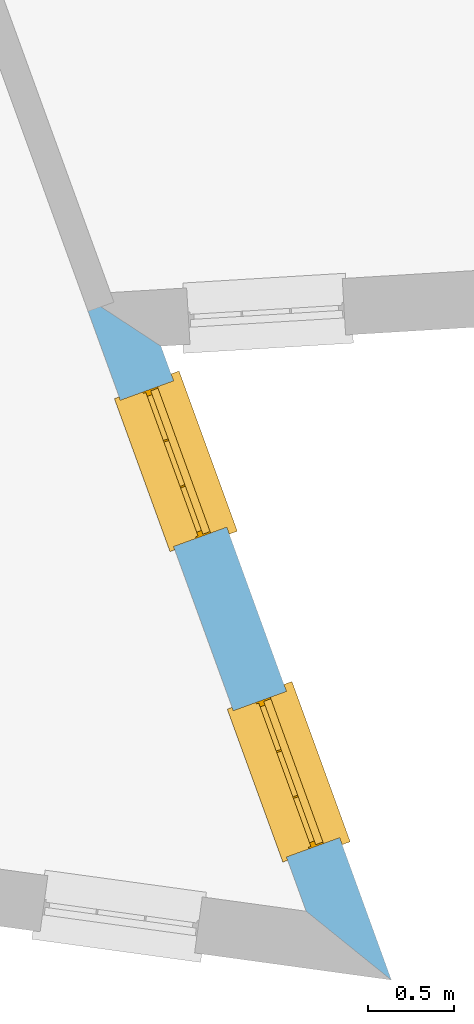
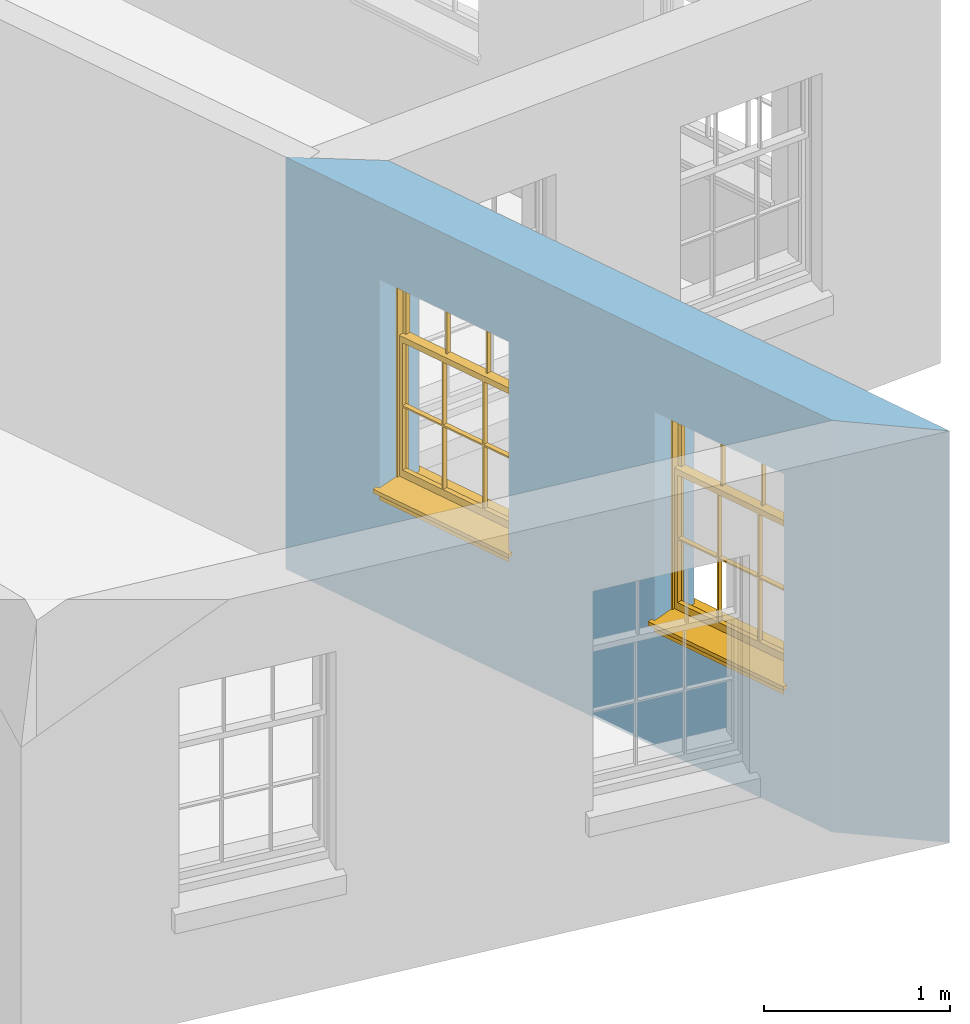
# One storey, part 4 of 12: 2 windows, 2 openings, plus 1 element that does not belong to this part.
"""IFC2X3 building model written with IfcOpenShell, lengths in metres."""

from ifc_helpers import new_model, si_unit, frame, origin, place, context, subcontext, project, spatial, polyline, outline, extrude, faceted_brep, material, layer, layer_set, layer_usage, element, fill, save


model = new_model("IFC2X3")

# Units and contexts
model_context = context("Model", 3, world=origin())
body_context = subcontext(model_context, "Body", "Model", "MODEL_VIEW")
ifc_project = project(units=[si_unit("PLANEANGLEUNIT", "RADIAN"), si_unit("MASSUNIT", "GRAM", prefix="KILO"), si_unit("FORCEUNIT", "NEWTON", prefix="KILO"), si_unit("LENGTHUNIT", "METRE")], contexts=[model_context])

# Site, building, storey
site_placement = place(None, origin())
site = spatial("IfcSite", under=ifc_project, at=site_placement, CompositionType="ELEMENT")
building_placement = place(None, origin())
building = spatial("IfcBuilding", under=site, at=building_placement, Name="Building plot-12", CompositionType="ELEMENT")
storey_placement = place(None, frame((0.0, 0.0, 6.45)))
storey = spatial("IfcBuildingStorey", under=building, at=storey_placement, Name="Floor 1", CompositionType="ELEMENT", Elevation=6.45)

# Wall, openings, windows
ifc_material = material(Name="Masonry")
ifc_layer = layer(ifc_material, 0.33, ventilated=False)
ifc_layer_set = layer_set([ifc_layer], Name="My Wall")
ifc_layer_usage = layer_usage(ifc_layer_set, "AXIS2", "NEGATIVE", 0.08)
wall_placement = place(storey_placement, origin())
wall = element("IfcWallStandardCase", 1, at=wall_placement, inside=storey, material=ifc_layer_usage, Name="exterior", context=body_context, shape_type="SweptSolid", body=[
    extrude(outline(polyline([(60.357257872223, 31.2577442307242), (60.8543376208598, 30.856304618938), (59.5092760501621, 34.5560013261806), (59.0480704661197, 34.8587662516055), (60.357257872223, 31.2577442307242)])), origin(), (0.0, 0.0, 1.0), 2.7),
])
opening_1_placement = place(storey_placement, frame((0.0, 0.0, 0.75)))
opening_1 = element("IfcOpeningElement", 2, at=opening_1_placement, cuts=wall, Name="Opening", ObjectType="Opening", context=body_context, shape_type="SweptSolid", body=[
    extrude(outline(polyline([(60.5526263615271, 31.6861849582538), (60.241697889756, 32.541417958928), (59.9315584499511, 32.4286636779561), (60.2424869217222, 31.5734306772819), (60.5526263615271, 31.6861849582538)])), origin(), (0.0, 0.0, 1.0), 1.445),
])
opening_2_placement = place(storey_placement, frame((0.0, 0.0, 0.75)))
opening_2 = element("IfcOpeningElement", 3, at=opening_2_placement, cuts=wall, Name="Opening", ObjectType="Opening", context=body_context, shape_type="SweptSolid", body=[
    extrude(outline(polyline([(59.8936842748883, 33.4986565367382), (59.5827558031172, 34.3538895374124), (59.2726163633123, 34.2411352564405), (59.5835448350833, 33.3859022557663), (59.8936842748883, 33.4986565367382)])), origin(), (0.0, 0.0, 1.0), 1.445),
])
window_1_placement = place(storey_placement, frame((60.3176722404628, 31.6007650484266, 0.75), z_axis=(0.0, 0.0, 1.0), x_axis=(-0.310928471771057, 0.855233000674151, 0.0)))
window_1 = element("IfcWindow", 4, at=window_1_placement, inside=storey, Name="living outside window", OverallHeight=1.445, OverallWidth=0.91, context=body_context, shape_type="Brep", held_by="IfcProductRepresentation", body=[
    faceted_brep([(0.876875, -0.105, 0.999097), (0.876875, -0.105, 1.411875), (0.9, -0.105, 1.435), (0.033125, -0.105, 1.411875), (0.033125, -0.105, 0.999097), (0.01, -0.105, 1.435), (0.033125, -0.135, 1.411875), (0.01, -0.135, 1.435), (0.033125, -0.135, 0.999097), (0.876875, -0.135, 1.411875), (0.876875, -0.135, 0.999097), (0.9, -0.135, 1.435), (0.033125, -0.105, 0.960972), (0.01, -0.105, 0.960972), (0.033125, -0.105, 0.548195), (0.876875, -0.105, 0.960972), (0.876875, -0.105, 0.548195), (0.9, -0.105, 0.960972), (0.876875, -0.105, 0.538195), (0.876875, -0.105, 0.125417), (0.9, -0.105, 0.077167), (0.033125, -0.105, 0.125417), (0.033125, -0.105, 0.538195), (0.01, -0.105, 0.077167), (0.9, -0.135, 0.960972), (0.01, -0.135, 0.960972), (-0.0425, -0.25, 0.01), (-0.0425, -0.3, 0.001667), (0.0, -0.25, 0.01), (0.9525, -0.25, 0.01), (0.91, -0.25, 0.01), (0.9525, -0.3, 0.001667), (-0.02, 0.08, 0.077167), (0.0, 0.08, 0.077167), (-0.02, 0.11, 0.077167), (0.0, -0.06, 0.077167), (0.01, -0.06, 0.077167), (0.91, -0.06, 0.077167), (0.91, 0.08, 0.077167), (0.9, -0.06, 0.077167), (0.93, 0.08, 0.077167), (0.93, 0.11, 0.077167), (0.01, -0.105, 0.999097), (0.01, -0.075, 0.999097), (0.9, -0.105, 0.999097), (0.9, -0.075, 0.999097), (0.876875, -0.075, 0.125417), (0.876875, -0.075, 0.538195), (0.9, -0.075, 0.077167), (0.876875, -0.075, 0.548195), (0.876875, -0.075, 0.960972), (0.033125, -0.075, 0.125417), (0.01, -0.075, 0.077167), (0.033125, -0.075, 0.538195), (0.033125, -0.075, 0.960972), (0.033125, -0.075, 0.548195), (-0.02, 0.08, 0.052167), (-0.02, 0.11, 0.052167), (0.93, 0.11, 0.052167), (0.93, 0.08, 0.052167), (0.91, 0.08, 0.052167), (0.0, 0.08, 0.052167), (0.91, -0.15, 0.026667), (0.0, -0.15, 0.026667), (-0.0425, -0.3, -0.123333), (0.9525, -0.3, -0.123333), (-0.0425, -0.25, -0.123333), (0.9525, -0.25, -0.123333), (0.01, -0.06, 1.435), (0.9, -0.06, 1.435), (0.0, -0.06, 1.445), (0.91, -0.06, 1.445), (0.01, -0.15, 0.077167), (0.9, -0.15, 0.077167), (0.592292, -0.105, 0.125417), (0.592292, -0.075, 0.125417), (0.317708, -0.075, 0.125417), (0.317708, -0.105, 0.125417), (0.592292, -0.105, 0.548195), (0.317708, -0.105, 0.548195), (0.317708, -0.105, 0.538195), (0.592292, -0.105, 0.538195), (0.592292, -0.075, 0.548195), (0.317708, -0.075, 0.548195), (0.602292, -0.075, 0.548195), (0.602292, -0.105, 0.548195), (0.317708, -0.075, 0.538195), (0.307708, -0.075, 0.125417), (0.307708, -0.075, 0.538195), (0.602292, -0.075, 0.538195), (0.602292, -0.075, 0.125417), (0.592292, -0.075, 0.538195), (0.307708, -0.075, 0.548195), (0.317708, -0.075, 0.960972), (0.307708, -0.075, 0.960972), (0.602292, -0.075, 0.960972), (0.592292, -0.075, 0.960972), (0.307708, -0.105, 0.538195), (0.307708, -0.105, 0.125417), (0.307708, -0.105, 0.548195), (0.307708, -0.105, 0.960972), (0.592292, -0.105, 0.960972), (0.317708, -0.105, 0.960972), (0.602292, -0.105, 0.960972), (0.602292, -0.105, 0.538195), (0.602292, -0.105, 0.125417), (0.317708, -0.135, 1.411875), (0.307708, -0.135, 1.411875), (0.307708, -0.135, 0.999097), (0.317708, -0.135, 0.999097), (0.602292, -0.135, 1.411875), (0.592292, -0.135, 1.411875), (0.592292, -0.135, 0.999097), (0.602292, -0.135, 0.999097), (0.317708, -0.105, 0.999097), (0.307708, -0.105, 0.999097), (0.307708, -0.105, 1.411875), (0.317708, -0.105, 1.411875), (0.602292, -0.105, 0.999097), (0.592292, -0.105, 0.999097), (0.592292, -0.105, 1.411875), (0.602292, -0.105, 1.411875), (0.91, -0.15, 1.445), (0.9, -0.15, 1.435), (0.01, -0.15, 1.435), (0.0, -0.15, 1.445), (0.91, -0.25, 0.0), (0.0, -0.25, 0.0), (0.91, 0.08, 0.0), (0.0, 0.08, 0.0)], [[[0, 1, 2]], [[3, 4, 5]], [[6, 7, 8]], [[9, 10, 11]], [[12, 13, 14]], [[15, 16, 17]], [[18, 19, 20]], [[21, 22, 23]], [[24, 15, 17]], [[13, 12, 25]], [[26, 27, 28]], [[29, 30, 31]], [[32, 33, 34]], [[35, 36, 33]], [[37, 38, 39]], [[40, 41, 38]], [[42, 4, 43]], [[44, 45, 0]], [[46, 47, 48]], [[49, 50, 45]], [[51, 52, 53]], [[54, 55, 43]], [[38, 33, 36, 39]], [[41, 34, 33, 38]], [[56, 32, 34, 57]], [[57, 34, 41, 58]], [[58, 41, 40, 59]], [[57, 58, 60, 61]], [[52, 48, 39, 36]], [[62, 63, 28, 30]], [[27, 31, 30, 28]], [[27, 64, 65, 31]], [[66, 67, 65, 64]], [[2, 5, 68, 69]], [[68, 70, 71, 69]], [[20, 23, 72, 73]], [[73, 72, 63, 62]], [[74, 75, 76, 77]], [[78, 79, 80, 81]], [[78, 82, 83, 79]], [[16, 49, 84, 85]], [[86, 76, 87, 88]], [[89, 90, 75, 91]], [[92, 88, 53, 55]], [[82, 91, 86, 83]], [[93, 83, 92, 94]], [[95, 84, 82, 96]], [[89, 84, 49, 47]], [[97, 88, 87, 98]], [[22, 53, 88, 97]], [[81, 91, 75, 74]], [[80, 86, 91, 81]], [[77, 76, 86, 80]], [[99, 92, 55, 14]], [[100, 94, 92, 99]], [[101, 96, 82, 78]], [[79, 83, 93, 102]], [[85, 84, 95, 103]], [[104, 89, 47, 18]], [[105, 90, 89, 104]], [[104, 18, 16, 85]], [[80, 97, 98, 77]], [[104, 81, 74, 105]], [[103, 101, 78, 85]], [[99, 14, 22, 97]], [[102, 100, 99, 79]], [[106, 107, 108, 109]], [[110, 111, 112, 113]], [[114, 115, 116, 117]], [[118, 119, 120, 121]], [[107, 116, 115, 108]], [[111, 120, 119, 112]], [[109, 114, 117, 106]], [[113, 118, 121, 110]], [[85, 78, 81, 104]], [[84, 89, 91, 82]], [[83, 86, 88, 92]], [[79, 99, 97, 80]], [[109, 112, 119, 114]], [[102, 93, 96, 101]], [[106, 117, 120, 111]], [[98, 87, 51, 21]], [[6, 3, 116, 107]], [[110, 121, 1, 9]], [[19, 46, 90, 105]], [[26, 66, 64, 27]], [[29, 31, 65, 67]], [[25, 24, 112, 109]], [[11, 7, 106, 111]], [[75, 48, 52, 76]], [[43, 45, 96, 93]], [[45, 43, 114, 119]], [[5, 2, 120, 117]], [[24, 25, 102, 101]], [[42, 5, 4]], [[2, 44, 0]], [[49, 45, 48, 47]], [[52, 43, 55, 53]], [[14, 13, 23, 22]], [[20, 17, 16, 18]], [[24, 11, 10]], [[25, 8, 7]], [[8, 4, 3, 6]], [[9, 1, 0, 10]], [[15, 50, 49, 16]], [[18, 47, 46, 19]], [[21, 51, 53, 22]], [[14, 55, 54, 12]], [[44, 2, 69, 45]], [[68, 5, 42, 43]], [[36, 35, 70, 68]], [[39, 69, 71, 37]], [[62, 122, 123, 73]], [[63, 72, 124, 125]], [[8, 108, 115, 4]], [[113, 10, 0, 118]], [[94, 100, 12, 54]], [[17, 20, 73, 24]], [[72, 23, 13, 25]], [[52, 36, 68, 43]], [[69, 39, 48, 45]], [[11, 24, 73, 123]], [[7, 124, 72, 25]], [[23, 77, 98]], [[98, 21, 23]], [[105, 74, 20]], [[20, 19, 105]], [[20, 74, 77, 23]], [[113, 112, 24]], [[24, 10, 113]], [[25, 109, 108]], [[108, 8, 25]], [[110, 9, 11]], [[11, 111, 110]], [[7, 6, 107]], [[107, 106, 7]], [[5, 117, 116]], [[116, 3, 5]], [[121, 120, 2]], [[2, 1, 121]], [[11, 123, 124, 7]], [[122, 125, 124, 123]], [[43, 93, 94]], [[94, 54, 43]], [[96, 45, 95]], [[50, 95, 45]], [[15, 103, 95, 50]], [[48, 75, 90]], [[90, 46, 48]], [[87, 76, 52]], [[52, 51, 87]], [[103, 15, 24]], [[24, 101, 103]], [[100, 102, 25]], [[25, 12, 100]], [[115, 114, 43]], [[43, 4, 115]], [[118, 0, 45]], [[45, 119, 118]], [[71, 70, 125, 122]], [[70, 35, 63, 125]], [[122, 62, 37, 71]], [[126, 67, 66, 127]], [[60, 58, 59]], [[38, 60, 59, 40]], [[61, 56, 57]], [[32, 56, 61, 33]], [[61, 60, 128, 129]], [[62, 60, 38, 37]], [[126, 128, 60, 62]], [[33, 61, 63, 35]], [[61, 129, 127, 63]], [[128, 126, 127, 129]], [[28, 127, 66, 26]], [[63, 127, 28]], [[29, 67, 126, 30]], [[30, 126, 62]]]),
])
fill(opening_1, window_1)
window_2_placement = place(storey_placement, frame((59.6587301538239, 33.413236626911, 0.75), z_axis=(0.0, 0.0, 1.0), x_axis=(-0.310928471771057, 0.855233000674147, 0.0)))
window_2 = element("IfcWindow", 5, at=window_2_placement, inside=storey, Name="living outside window", OverallHeight=1.445, OverallWidth=0.91, context=body_context, shape_type="Brep", held_by="IfcProductRepresentation", body=[
    faceted_brep([(0.876875, -0.105, 0.999097), (0.876875, -0.105, 1.411875), (0.9, -0.105, 1.435), (0.033125, -0.105, 1.411875), (0.033125, -0.105, 0.999097), (0.01, -0.105, 1.435), (0.033125, -0.135, 1.411875), (0.01, -0.135, 1.435), (0.033125, -0.135, 0.999097), (0.876875, -0.135, 1.411875), (0.876875, -0.135, 0.999097), (0.9, -0.135, 1.435), (0.033125, -0.105, 0.960972), (0.01, -0.105, 0.960972), (0.033125, -0.105, 0.548195), (0.876875, -0.105, 0.960972), (0.876875, -0.105, 0.548195), (0.9, -0.105, 0.960972), (0.876875, -0.105, 0.538195), (0.876875, -0.105, 0.125417), (0.9, -0.105, 0.077167), (0.033125, -0.105, 0.125417), (0.033125, -0.105, 0.538195), (0.01, -0.105, 0.077167), (0.9, -0.135, 0.960972), (0.01, -0.135, 0.960972), (-0.0425, -0.25, 0.01), (-0.0425, -0.3, 0.001667), (0.0, -0.25, 0.01), (0.9525, -0.25, 0.01), (0.91, -0.25, 0.01), (0.9525, -0.3, 0.001667), (-0.02, 0.08, 0.077167), (0.0, 0.08, 0.077167), (-0.02, 0.11, 0.077167), (0.0, -0.06, 0.077167), (0.01, -0.06, 0.077167), (0.91, -0.06, 0.077167), (0.91, 0.08, 0.077167), (0.9, -0.06, 0.077167), (0.93, 0.08, 0.077167), (0.93, 0.11, 0.077167), (0.01, -0.105, 0.999097), (0.01, -0.075, 0.999097), (0.9, -0.105, 0.999097), (0.9, -0.075, 0.999097), (0.876875, -0.075, 0.125417), (0.876875, -0.075, 0.538195), (0.9, -0.075, 0.077167), (0.876875, -0.075, 0.548195), (0.876875, -0.075, 0.960972), (0.033125, -0.075, 0.125417), (0.01, -0.075, 0.077167), (0.033125, -0.075, 0.538195), (0.033125, -0.075, 0.960972), (0.033125, -0.075, 0.548195), (-0.02, 0.08, 0.052167), (-0.02, 0.11, 0.052167), (0.93, 0.11, 0.052167), (0.93, 0.08, 0.052167), (0.91, 0.08, 0.052167), (0.0, 0.08, 0.052167), (0.91, -0.15, 0.026667), (0.0, -0.15, 0.026667), (-0.0425, -0.3, -0.123333), (0.9525, -0.3, -0.123333), (-0.0425, -0.25, -0.123333), (0.9525, -0.25, -0.123333), (0.01, -0.06, 1.435), (0.9, -0.06, 1.435), (0.0, -0.06, 1.445), (0.91, -0.06, 1.445), (0.01, -0.15, 0.077167), (0.9, -0.15, 0.077167), (0.592292, -0.105, 0.125417), (0.592292, -0.075, 0.125417), (0.317708, -0.075, 0.125417), (0.317708, -0.105, 0.125417), (0.592292, -0.105, 0.548195), (0.317708, -0.105, 0.548195), (0.317708, -0.105, 0.538195), (0.592292, -0.105, 0.538195), (0.592292, -0.075, 0.548195), (0.317708, -0.075, 0.548195), (0.602292, -0.075, 0.548195), (0.602292, -0.105, 0.548195), (0.317708, -0.075, 0.538195), (0.307708, -0.075, 0.125417), (0.307708, -0.075, 0.538195), (0.602292, -0.075, 0.538195), (0.602292, -0.075, 0.125417), (0.592292, -0.075, 0.538195), (0.307708, -0.075, 0.548195), (0.317708, -0.075, 0.960972), (0.307708, -0.075, 0.960972), (0.602292, -0.075, 0.960972), (0.592292, -0.075, 0.960972), (0.307708, -0.105, 0.538195), (0.307708, -0.105, 0.125417), (0.307708, -0.105, 0.548195), (0.307708, -0.105, 0.960972), (0.592292, -0.105, 0.960972), (0.317708, -0.105, 0.960972), (0.602292, -0.105, 0.960972), (0.602292, -0.105, 0.538195), (0.602292, -0.105, 0.125417), (0.317708, -0.135, 1.411875), (0.307708, -0.135, 1.411875), (0.307708, -0.135, 0.999097), (0.317708, -0.135, 0.999097), (0.602292, -0.135, 1.411875), (0.592292, -0.135, 1.411875), (0.592292, -0.135, 0.999097), (0.602292, -0.135, 0.999097), (0.317708, -0.105, 0.999097), (0.307708, -0.105, 0.999097), (0.307708, -0.105, 1.411875), (0.317708, -0.105, 1.411875), (0.602292, -0.105, 0.999097), (0.592292, -0.105, 0.999097), (0.592292, -0.105, 1.411875), (0.602292, -0.105, 1.411875), (0.91, -0.15, 1.445), (0.9, -0.15, 1.435), (0.01, -0.15, 1.435), (0.0, -0.15, 1.445), (0.91, -0.25, 0.0), (0.0, -0.25, 0.0), (0.91, 0.08, 0.0), (0.0, 0.08, 0.0)], [[[0, 1, 2]], [[3, 4, 5]], [[6, 7, 8]], [[9, 10, 11]], [[12, 13, 14]], [[15, 16, 17]], [[18, 19, 20]], [[21, 22, 23]], [[24, 15, 17]], [[13, 12, 25]], [[26, 27, 28]], [[29, 30, 31]], [[32, 33, 34]], [[35, 36, 33]], [[37, 38, 39]], [[40, 41, 38]], [[42, 4, 43]], [[44, 45, 0]], [[46, 47, 48]], [[49, 50, 45]], [[51, 52, 53]], [[54, 55, 43]], [[38, 33, 36, 39]], [[41, 34, 33, 38]], [[56, 32, 34, 57]], [[57, 34, 41, 58]], [[58, 41, 40, 59]], [[57, 58, 60, 61]], [[52, 48, 39, 36]], [[62, 63, 28, 30]], [[27, 31, 30, 28]], [[27, 64, 65, 31]], [[66, 67, 65, 64]], [[2, 5, 68, 69]], [[68, 70, 71, 69]], [[20, 23, 72, 73]], [[73, 72, 63, 62]], [[74, 75, 76, 77]], [[78, 79, 80, 81]], [[78, 82, 83, 79]], [[16, 49, 84, 85]], [[86, 76, 87, 88]], [[89, 90, 75, 91]], [[92, 88, 53, 55]], [[82, 91, 86, 83]], [[93, 83, 92, 94]], [[95, 84, 82, 96]], [[89, 84, 49, 47]], [[97, 88, 87, 98]], [[22, 53, 88, 97]], [[81, 91, 75, 74]], [[80, 86, 91, 81]], [[77, 76, 86, 80]], [[99, 92, 55, 14]], [[100, 94, 92, 99]], [[101, 96, 82, 78]], [[79, 83, 93, 102]], [[85, 84, 95, 103]], [[104, 89, 47, 18]], [[105, 90, 89, 104]], [[104, 18, 16, 85]], [[80, 97, 98, 77]], [[104, 81, 74, 105]], [[103, 101, 78, 85]], [[99, 14, 22, 97]], [[102, 100, 99, 79]], [[106, 107, 108, 109]], [[110, 111, 112, 113]], [[114, 115, 116, 117]], [[118, 119, 120, 121]], [[107, 116, 115, 108]], [[111, 120, 119, 112]], [[109, 114, 117, 106]], [[113, 118, 121, 110]], [[85, 78, 81, 104]], [[84, 89, 91, 82]], [[83, 86, 88, 92]], [[79, 99, 97, 80]], [[109, 112, 119, 114]], [[102, 93, 96, 101]], [[106, 117, 120, 111]], [[98, 87, 51, 21]], [[6, 3, 116, 107]], [[110, 121, 1, 9]], [[19, 46, 90, 105]], [[26, 66, 64, 27]], [[29, 31, 65, 67]], [[25, 24, 112, 109]], [[11, 7, 106, 111]], [[75, 48, 52, 76]], [[43, 45, 96, 93]], [[45, 43, 114, 119]], [[5, 2, 120, 117]], [[24, 25, 102, 101]], [[42, 5, 4]], [[2, 44, 0]], [[49, 45, 48, 47]], [[52, 43, 55, 53]], [[14, 13, 23, 22]], [[20, 17, 16, 18]], [[24, 11, 10]], [[25, 8, 7]], [[8, 4, 3, 6]], [[9, 1, 0, 10]], [[15, 50, 49, 16]], [[18, 47, 46, 19]], [[21, 51, 53, 22]], [[14, 55, 54, 12]], [[44, 2, 69, 45]], [[68, 5, 42, 43]], [[36, 35, 70, 68]], [[39, 69, 71, 37]], [[62, 122, 123, 73]], [[63, 72, 124, 125]], [[8, 108, 115, 4]], [[113, 10, 0, 118]], [[94, 100, 12, 54]], [[17, 20, 73, 24]], [[72, 23, 13, 25]], [[52, 36, 68, 43]], [[69, 39, 48, 45]], [[11, 24, 73, 123]], [[7, 124, 72, 25]], [[23, 77, 98]], [[98, 21, 23]], [[105, 74, 20]], [[20, 19, 105]], [[20, 74, 77, 23]], [[113, 112, 24]], [[24, 10, 113]], [[25, 109, 108]], [[108, 8, 25]], [[110, 9, 11]], [[11, 111, 110]], [[7, 6, 107]], [[107, 106, 7]], [[5, 117, 116]], [[116, 3, 5]], [[121, 120, 2]], [[2, 1, 121]], [[11, 123, 124, 7]], [[122, 125, 124, 123]], [[43, 93, 94]], [[94, 54, 43]], [[96, 45, 95]], [[50, 95, 45]], [[15, 103, 95, 50]], [[48, 75, 90]], [[90, 46, 48]], [[87, 76, 52]], [[52, 51, 87]], [[103, 15, 24]], [[24, 101, 103]], [[100, 102, 25]], [[25, 12, 100]], [[115, 114, 43]], [[43, 4, 115]], [[118, 0, 45]], [[45, 119, 118]], [[71, 70, 125, 122]], [[70, 35, 63, 125]], [[122, 62, 37, 71]], [[126, 67, 66, 127]], [[60, 58, 59]], [[38, 60, 59, 40]], [[61, 56, 57]], [[32, 56, 61, 33]], [[61, 60, 128, 129]], [[62, 60, 38, 37]], [[126, 128, 60, 62]], [[33, 61, 63, 35]], [[61, 129, 127, 63]], [[128, 126, 127, 129]], [[28, 127, 66, 26]], [[63, 127, 28]], [[29, 67, 126, 30]], [[30, 126, 62]]]),
])
fill(opening_2, window_2)

save(model, "model.ifc")
